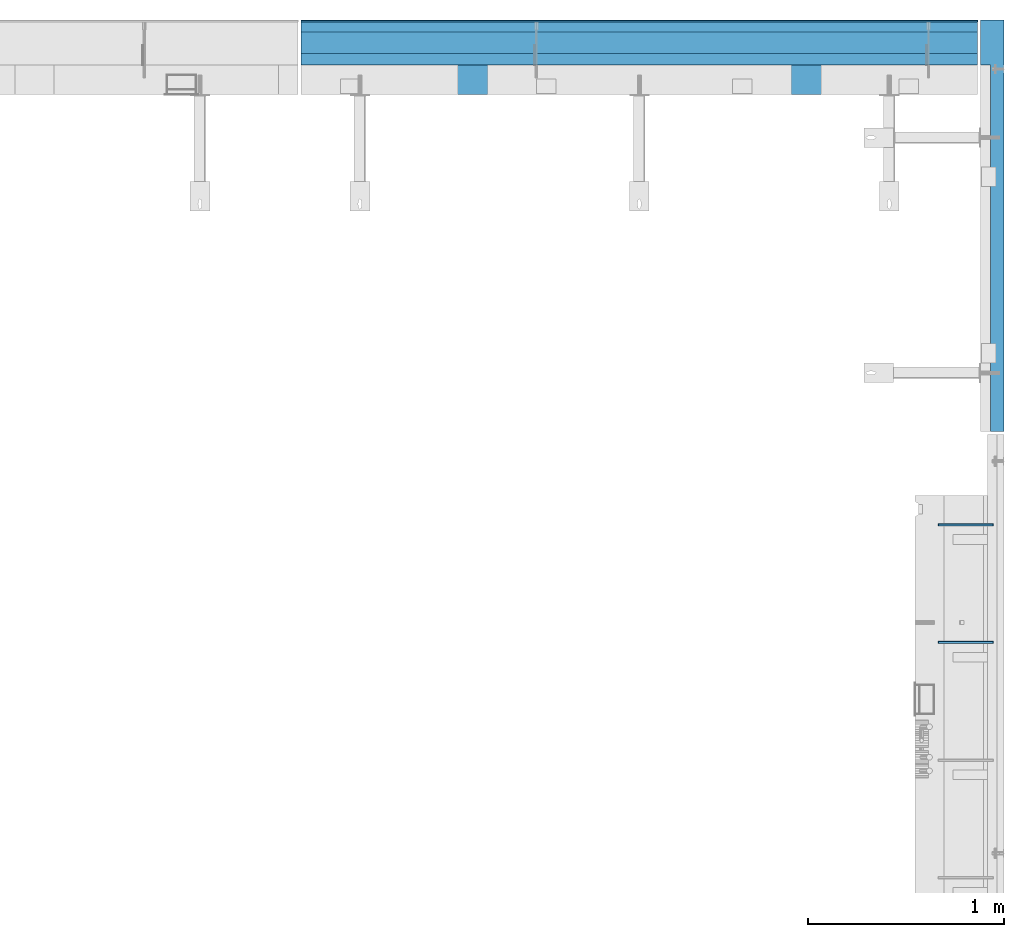
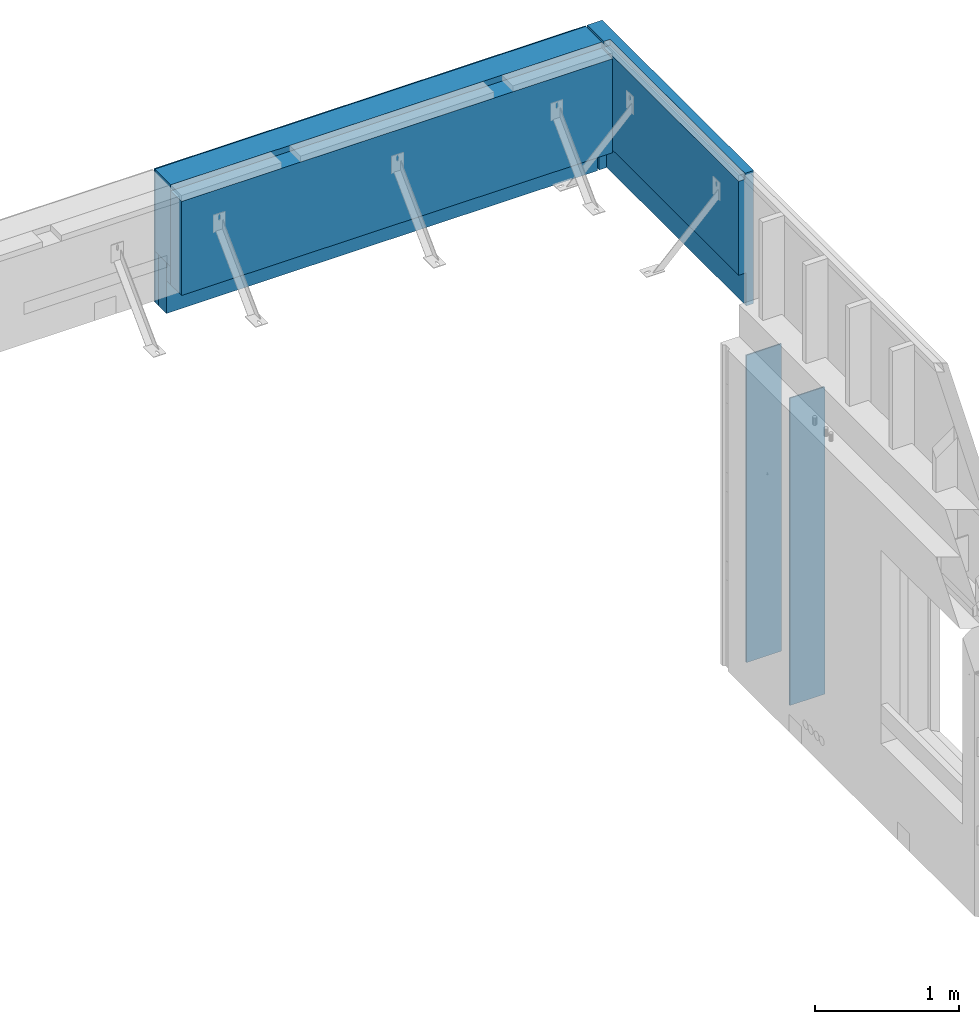
# One storey, part 82 of 153: 9 walls, 4 elements without a shape of their own.
"""IFC2X3 building model written with IfcOpenShell, lengths in millimetres."""

from ifc_helpers import new_model, si_unit, frame, origin_with_axes, place, context, subcontext, project, spatial, faceted_brep, material, type_object, element, aggregate, save


model = new_model("IFC2X3")

# Units and contexts
model_context = context("Model", 3, precision=1e-05, world=origin_with_axes())
body_context = subcontext(model_context, "Body", "Model", "MODEL_VIEW")
ifc_project = project(units=[si_unit("LENGTHUNIT", "METRE", prefix="MILLI"), si_unit("AREAUNIT", "SQUARE_METRE"), si_unit("VOLUMEUNIT", "CUBIC_METRE"), si_unit("MASSUNIT", "GRAM", prefix="KILO"), si_unit("TIMEUNIT", "SECOND"), si_unit("PLANEANGLEUNIT", "RADIAN"), si_unit("SOLIDANGLEUNIT", "STERADIAN"), si_unit("THERMODYNAMICTEMPERATUREUNIT", "DEGREE_CELSIUS"), si_unit("LUMINOUSINTENSITYUNIT", "LUMEN")], contexts=[model_context])

# Site, building, storey
site_placement = place(None, origin_with_axes())
site = spatial("IfcSite", under=ifc_project, at=site_placement, CompositionType="ELEMENT")
building_placement = place(site_placement, origin_with_axes())
building = spatial("IfcBuilding", under=site, at=building_placement, CompositionType="ELEMENT")
storey_placement = place(building_placement, origin_with_axes())
storey = spatial("IfcBuildingStorey", under=building, at=storey_placement, Name="8", CompositionType="ELEMENT", Elevation=0.0)

# Assembly, walls
assembly_1_placement = place(storey_placement, origin_with_axes())
assembly_1 = element("IfcElementAssembly", 1, at=assembly_1_placement, inside=storey, AssemblyPlace="NOTDEFINED", PredefinedType="REINFORCEMENT_UNIT")
ifc_material_1 = material(Name="Undefined")
wall_type_1 = type_object("IfcWallType", PredefinedType="NOTDEFINED")
wall_1_placement = place(assembly_1_placement, frame((35030.0, 19825.0002441406, 101115.0), z_axis=(0.0, 0.0, 1.0), x_axis=(1.0, 0.0, 0.0)))
wall_1 = element("IfcWall", 2, at=wall_1_placement, type_object=wall_type_1, material=ifc_material_1, Name="(PD)", context=body_context, shape_type="Brep", body=[
    faceted_brep([(0.0, 5.0, -1300.0), (0.0, 5.0, 1300.0), (280.0, 5.0, 1300.0), (280.0, 5.0, -1300.0), (0.0, -5.0, 1300.0), (280.0, -5.0, 1300.0), (0.0, -5.0, -1300.0), (280.0, -5.0, -1300.0)], [[[0, 1, 2, 3]], [[1, 4, 5, 2]], [[4, 6, 7, 5]], [[6, 0, 3, 7]], [[5, 7, 3, 2]], [[6, 4, 1, 0]]]),
])
wall_2_placement = place(assembly_1_placement, frame((35030.0, 20425.0002441406, 101115.0), z_axis=(0.0, 0.0, 1.0), x_axis=(1.0, 0.0, 0.0)))
wall_2 = element("IfcWall", 3, at=wall_2_placement, type_object=wall_type_1, material=ifc_material_1, Name="(PD)", context=body_context, shape_type="Brep", body=[
    faceted_brep([(0.0, 5.0, -1300.0), (0.0, 5.0, 1300.0), (280.0, 5.0, 1300.0), (280.0, 5.0, -1300.0), (0.0, -5.0, 1300.0), (280.0, -5.0, 1300.0), (0.0, -5.0, -1300.0), (280.0, -5.0, -1300.0)], [[[0, 1, 2, 3]], [[1, 4, 5, 2]], [[4, 6, 7, 5]], [[6, 0, 3, 7]], [[5, 7, 3, 2]], [[6, 4, 1, 0]]]),
])
aggregate(assembly_1, [wall_1, wall_2])

assembly_2_placement = place(storey_placement, origin_with_axes())
assembly_2 = element("IfcElementAssembly", 4, at=assembly_2_placement, inside=storey, AssemblyPlace="NOTDEFINED", PredefinedType="REINFORCEMENT_UNIT")
ifc_material_2 = material(Name="CONCRETE/C25/30")
wall_type_2 = type_object("IfcWallType", PredefinedType="NOTDEFINED")
wall_3_placement = place(assembly_2_placement, frame((35229.9963435006, 22800.0013006488, 102800.0), z_axis=(0.0, 0.0, 1.0), x_axis=(-1.0, 3.00000001838171e-08, 0.0)))
wall_3 = element("IfcWall", 5, at=wall_3_placement, type_object=wall_type_2, material=ifc_material_2, context=body_context, shape_type="Brep", body=[
    faceted_brep([(9.09494701772928e-13, 30.0000000000036, -75.0), (9.09494701772928e-13, 30.0000000000036, 75.0), (3449.9963963128, 29.9999999999927, 75.0), (3449.9963963128, 29.9999999999927, -75.0), (9.09494701772928e-13, -29.9999999999964, 75.0), (3449.9963963128, -30.0000000000036, 75.0), (9.09494701772928e-13, -29.9999999999964, -75.0), (3449.9963963128, -30.0000000000036, -75.0)], [[[0, 1, 2, 3]], [[1, 4, 5, 2]], [[4, 6, 7, 5]], [[6, 0, 3, 7]], [[5, 7, 3, 2]], [[6, 4, 1, 0]]]),
])
wall_type_3 = type_object("IfcWallType", PredefinedType="NOTDEFINED")
wall_4_placement = place(assembly_2_placement, frame((35229.9963435006, 22885.0013006488, 102660.0), z_axis=(0.0, 0.0, 1.0), x_axis=(-1.0, 3.00000001838171e-08, 0.0)))
wall_4 = element("IfcWall", 6, at=wall_4_placement, type_object=wall_type_3, material=ifc_material_2, context=body_context, shape_type="Brep", body=[
    faceted_brep([(9.09494701772928e-13, 55.0, -215.0), (9.09494701772928e-13, 55.0, 215.0), (3449.9963963128, 54.9999999999964, 215.0), (3449.9963963128, 54.9999999999964, -215.0), (0.0, -55.0, 215.0), (3449.9963963128, -55.0000000000036, 215.0), (0.0, -55.0, -215.0), (3449.9963963128, -55.0000000000036, -215.0)], [[[0, 1, 2, 3]], [[1, 4, 5, 2]], [[4, 6, 7, 5]], [[6, 0, 3, 7]], [[5, 7, 3, 2]], [[6, 4, 1, 0]]]),
])
ifc_material_3 = material()
wall_type_4 = type_object("IfcWallType", PredefinedType="NOTDEFINED")
wall_5_placement = place(assembly_2_placement, frame((35229.9963227656, 22965.0013006488, 102660.0), z_axis=(0.0, 0.0, 1.0), x_axis=(-1.0, 3.00000001838171e-08, 0.0)))
wall_5 = element("IfcWall", 7, at=wall_5_placement, type_object=wall_type_4, material=ifc_material_3, context=body_context, shape_type="Brep", body=[
    faceted_brep([(-9.09494701772928e-13, 25.0, -215.0), (-9.09494701772928e-13, 25.0, 215.0), (3449.99639631279, 25.0, 215.0), (3449.99639631279, 25.0, -215.0), (-9.09494701772928e-13, -25.0000000000036, 215.0), (3449.99639631279, -25.0000000000036, 215.0), (-9.09494701772928e-13, -25.0000000000036, -215.0), (3449.99639631279, -25.0000000000036, -215.0)], [[[0, 1, 2, 3]], [[1, 4, 5, 2]], [[4, 6, 7, 5]], [[6, 0, 3, 7]], [[5, 7, 3, 2]], [[6, 4, 1, 0]]]),
])

# Assembly, wall
assembly_3_placement = place(storey_placement, origin_with_axes())
assembly_3 = element("IfcElementAssembly", 8, at=assembly_3_placement, inside=storey, AssemblyPlace="NOTDEFINED", PredefinedType="REINFORCEMENT_UNIT")
ifc_material_4 = material(Name="CONCRETE/C30/37")
wall_type_5 = type_object("IfcWallType", PredefinedType="NOTDEFINED")
wall_6_placement = place(assembly_3_placement, frame((35304.9969543158, 23000.0099170723, 103007.5), z_axis=(0.0, 0.0, 1.0), x_axis=(1.19800000174933e-06, -0.999999999999282, 0.0)))
wall_6 = element("IfcWall", 9, at=wall_6_placement, type_object=wall_type_5, material=ifc_material_4, context=body_context, shape_type="Brep", body=[
    faceted_brep([(2100.00655944323, -59.9999999999927, -282.5), (167.003051757642, -60.000230798214, -282.5), (167.003134677641, -0.000230798264965415, -282.5), (2100.00655875899, -0.00290220900205895, -282.5), (167.003134677641, -0.000230798264965415, -562.5), (167.003051757642, -59.9999999999927, -562.5), (2100.00655944323, -0.00290220900205895, -562.5), (229.999999996147, -59.9999999999927, 562.5), (229.999999996147, -60.0003179011183, 512.5), (229.999991496148, -10.000317901111, 512.5), (229.999991496148, -10.000317901111, 562.5), (2100.00655094369, -10.0000000000073, 512.5), (2100.00655944323, -59.9999999999927, 512.5), (2100.00655944323, -10.0, 562.5), (2100.00655944323, 60.0000000000073, 562.5), (0.0, 60.0000000000073, 562.5), (-3.63797880709171e-12, -59.9999999999927, 562.5), (0.0, 60.0000000000073, -562.5), (2100.00655944323, 60.0000000000073, -562.5), (-3.63797880709171e-12, -59.9999999999927, -562.5)], [[[0, 1, 2, 3]], [[4, 2, 1, 5]], [[6, 3, 2, 4]], [[7, 8, 9, 10]], [[11, 9, 8, 12]], [[10, 9, 11, 13]], [[14, 15, 16, 7, 10, 13]], [[17, 15, 14, 18]], [[19, 16, 15, 17]], [[12, 8, 7, 16, 19, 5, 1, 0]], [[18, 14, 13, 11, 12, 0, 3, 6]], [[19, 17, 18, 6, 4, 5]]]),
])
aggregate(assembly_3, [wall_6])

assembly_4_placement = place(assembly_2_placement, origin_with_axes())
assembly_4 = element("IfcElementAssembly", 10, at=assembly_4_placement, Name="Steel Assembly", AssemblyPlace="NOTDEFINED", PredefinedType="NOTDEFINED")
wall_type_6 = type_object("IfcWallType", PredefinedType="NOTDEFINED")
wall_7_placement = place(assembly_4_placement, frame((31779.9999057181, 22880.0000000002, 103222.5), z_axis=(0.0, 0.0, 1.0), x_axis=(1.0, 0.0, 0.0)))
wall_7 = element("IfcWall", 11, at=wall_7_placement, type_object=wall_type_6, material=ifc_material_3, context=body_context, shape_type="Brep", body=[
    faceted_brep([(-3.63797880709171e-12, 110.0, -347.5), (-3.63797880709171e-12, 110.0, 347.5), (3449.9963963128, 110.0, 347.5), (3449.9963963128, 110.0, -347.5), (-3.63797880709171e-12, -110.0, 347.5), (3449.9963963128, -110.0, 347.5), (-3.63797880709171e-12, -110.0, -347.5), (3449.9963963128, -110.0, -347.5)], [[[0, 1, 2, 3]], [[1, 4, 5, 2]], [[4, 6, 7, 5]], [[6, 0, 3, 7]], [[5, 7, 3, 2]], [[6, 4, 1, 0]]]),
])
aggregate(assembly_4, [wall_7])

# Wall
ifc_material_5 = material()
wall_type_7 = type_object("IfcWallType", PredefinedType="NOTDEFINED")
wall_8_placement = place(assembly_2_placement, frame((31779.9998640874, 22995.0000000003, 103007.5), z_axis=(0.0, 0.0, 1.0), x_axis=(1.0, 0.0, 0.0)))
wall_8 = element("IfcWall", 12, at=wall_8_placement, type_object=wall_type_7, material=ifc_material_5, context=body_context, shape_type="Brep", body=[
    faceted_brep([(0.0, 5.00000000000364, -562.5), (0.0, 5.00000000000364, 562.5), (3449.99639461072, 5.00000000000364, 562.5), (3449.99639461072, 5.00000000000364, -562.5), (0.0, -4.99999999999636, 562.5), (3449.99639461071, -4.99999999999636, 562.5), (0.0, -4.99999999999636, -562.5), (3449.99639461071, -4.99999999999636, -562.5)], [[[0, 1, 2, 3]], [[1, 4, 5, 2]], [[4, 6, 7, 5]], [[6, 0, 3, 7]], [[5, 7, 3, 2]], [[6, 4, 1, 0]]]),
])

wall_type_8 = type_object("IfcWallType", PredefinedType="NOTDEFINED")
wall_9_placement = place(assembly_2_placement, frame((31779.9999728033, 22695.0000000001, 103122.5), z_axis=(0.0, 0.0, 1.0), x_axis=(1.0, 0.0, 0.0)))
wall_9 = element("IfcWall", 13, at=wall_9_placement, type_object=wall_type_8, material=ifc_material_2, context=body_context, shape_type="Brep", body=[
    faceted_brep([(0.0, 75.0000000000036, -397.5), (0.0, 75.0000000000036, 397.5), (3449.99639893862, 75.0000000000036, 397.5), (3449.99639893862, 75.0000000000036, -397.5), (0.0, -75.0, 397.5), (3449.99639893861, -75.0, 397.5), (0.0, -75.0, -397.5), (3449.99639893861, -75.0, -397.5)], [[[0, 1, 2, 3]], [[1, 4, 5, 2]], [[4, 6, 7, 5]], [[6, 0, 3, 7]], [[5, 7, 3, 2]], [[6, 4, 1, 0]]]),
])

aggregate(assembly_2, [wall_5, wall_3, wall_4, assembly_4, wall_8, wall_9])

save(model, "model.ifc")
